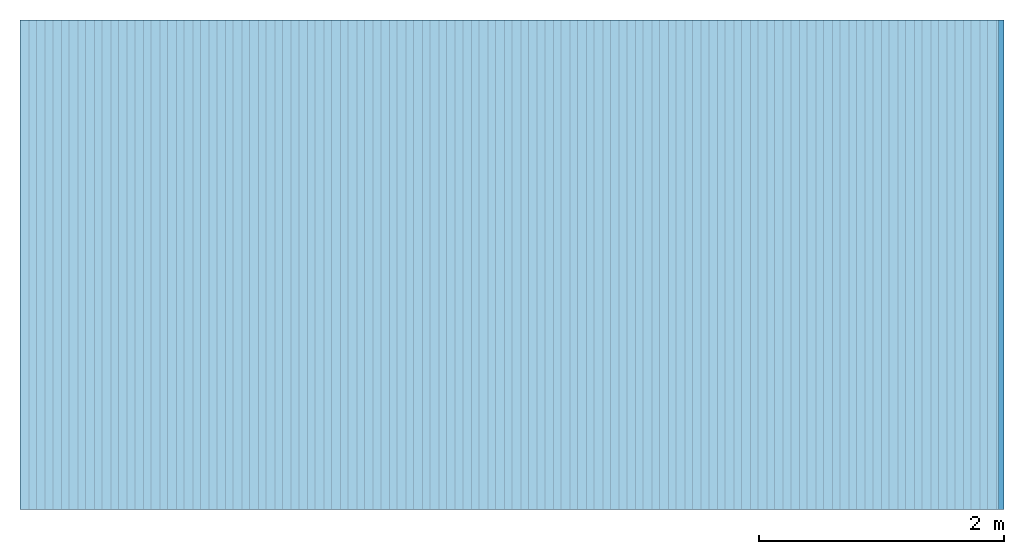
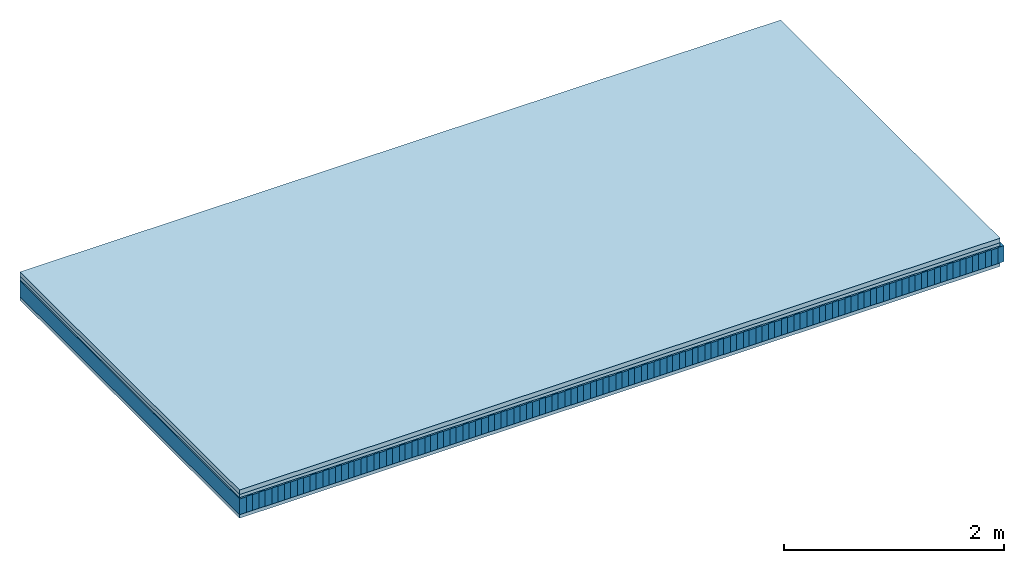
# One storey: 4 plates, 2 members, 1 element without a shape of its own.
"""IFC4 building model written with IfcOpenShell, lengths in metres."""

from ifc_helpers import new_model, si_unit, derived_unit, direction, frame, frame_2d, origin, origin_with_axes, place, context, project, spatial, rectangle, extrude, material, layer, layer_set, type_object, element, aggregate, save


model = new_model("IFC4")

# Units and contexts
plan_context = context("Plan", 3, precision=1e-05, world=origin(), true_north=direction((0.0, 1.0)))
model_context = context("Model", 3, precision=1e-05, world=origin(), true_north=direction((0.0, 1.0)))
ifc_project = project(units=[si_unit("LENGTHUNIT", "METRE"), derived_unit("SOUNDPRESSUREUNIT", [(si_unit("PRESSUREUNIT", "PASCAL", prefix="MICRO"), 0)]), si_unit("ENERGYUNIT", "JOULE", prefix="MEGA"), si_unit("MASSUNIT", "GRAM", prefix="KILO"), derived_unit("THERMALTRANSMITTANCEUNIT", [(si_unit("POWERUNIT", "WATT"), 1), (si_unit("AREAUNIT", "SQUARE_METRE"), -1), (si_unit("THERMODYNAMICTEMPERATUREUNIT", "KELVIN"), -1)]), derived_unit("AREADENSITYUNIT", [(si_unit("MASSUNIT", "GRAM", prefix="KILO"), 1), (si_unit("AREAUNIT", "SQUARE_METRE"), -1)]), derived_unit("USERDEFINED", [(si_unit("ENERGYUNIT", "JOULE", prefix="MEGA"), 1), (si_unit("AREAUNIT", "SQUARE_METRE"), -1)])], contexts=[plan_context, model_context])

# Site, building, storey
site = spatial("IfcSite", under=ifc_project)
building_placement = place(None, origin())
building = spatial("IfcBuilding", under=site, at=building_placement)
storey_placement = place(building_placement, origin())
storey = spatial("IfcBuildingStorey", under=building, at=storey_placement)

# Slab, members, plates
ifc_material_1 = material(Name="Cement screed", Category="04.006")
ifc_layer_1 = layer(ifc_material_1, 0.05, Name="On-material")
ifc_material_2 = material(Name="EP1, 40/35mm")
ifc_layer_2 = layer(ifc_material_2, 0.035, Name="Impact sound insulation")
ifc_material_3 = material(Name="Standard-n", Category="10.009")
ifc_layer_3 = layer(ifc_material_3, 0.015, Name="Additional insulation")
ifc_material_4 = material(Name="Rigid, of the art")
ifc_layer_4 = layer(ifc_material_4, 0.0, Name="Bond")
ifc_layer_5 = layer(None, 0.175, Name="Supporting structure")
ifc_layer_6 = layer(ifc_material_4, 0.0, Name="Bond")
ifc_material_5 = material(Name="panel on the underside HBF 40mm (20+20mm)", Category="07.001")
ifc_layer_7 = layer(ifc_material_5, 0.039, Name="Lower layer 1")
ifc_layer_set = layer_set([ifc_layer_1, ifc_layer_2, ifc_layer_3, ifc_layer_4, ifc_layer_5, ifc_layer_6, ifc_layer_7])
slab_type = type_object("IfcSlabType", Name="A0045", PredefinedType="NOTDEFINED", material=ifc_layer_set)
slab_placement = place(None, frame((0.0, 0.0, 0.0), z_axis=(0.0, 0.0, -1.0), x_axis=(1.0, 0.0, 0.0)))
slab = element("IfcSlab", 1, at=slab_placement, inside=storey, type_object=slab_type, material=ifc_layer_set, Name="Slab #1")
ifc_material_6 = material(Name="Ribs Q3")
member_1_placement = place(slab_placement, origin())
member_1 = element("IfcMember", 2, at=member_1_placement, material=ifc_material_6, Name="Supporting structure", context=plan_context, shape_type="SweptSolid", body=[
    extrude(rectangle(XDim=0.071666666666667, YDim=0.175, at=frame_2d((0.0358333333333335, 0.0875), x_axis=(1.0, 0.0))), frame((0.0, 4.0, 0.1), z_axis=(0.0, -1.0, 0.0), x_axis=(1.0, 0.0, 0.0)), (0.0, 0.0, 1.0), 4.0),
    extrude(rectangle(XDim=0.071666666666667, YDim=0.175, at=frame_2d((0.0358333333333335, 0.0875), x_axis=(1.0, 0.0))), frame((0.134, 4.0, 0.1), z_axis=(0.0, -1.0, 0.0), x_axis=(1.0, 0.0, 0.0)), (0.0, 0.0, 1.0), 4.0),
    extrude(rectangle(XDim=0.071666666666667, YDim=0.175, at=frame_2d((0.0358333333333335, 0.0875), x_axis=(1.0, 0.0))), frame((0.268, 4.0, 0.1), z_axis=(0.0, -1.0, 0.0), x_axis=(1.0, 0.0, 0.0)), (0.0, 0.0, 1.0), 4.0),
    extrude(rectangle(XDim=0.071666666666667, YDim=0.175, at=frame_2d((0.0358333333333335, 0.0875), x_axis=(1.0, 0.0))), frame((0.402, 4.0, 0.1), z_axis=(0.0, -1.0, 0.0), x_axis=(1.0, 0.0, 0.0)), (0.0, 0.0, 1.0), 4.0),
    extrude(rectangle(XDim=0.071666666666667, YDim=0.175, at=frame_2d((0.0358333333333335, 0.0875), x_axis=(1.0, 0.0))), frame((0.536, 4.0, 0.1), z_axis=(0.0, -1.0, 0.0), x_axis=(1.0, 0.0, 0.0)), (0.0, 0.0, 1.0), 4.0),
    extrude(rectangle(XDim=0.071666666666667, YDim=0.175, at=frame_2d((0.0358333333333335, 0.0875), x_axis=(1.0, 0.0))), frame((0.67, 4.0, 0.1), z_axis=(0.0, -1.0, 0.0), x_axis=(1.0, 0.0, 0.0)), (0.0, 0.0, 1.0), 4.0),
    extrude(rectangle(XDim=0.071666666666667, YDim=0.175, at=frame_2d((0.0358333333333335, 0.0875), x_axis=(1.0, 0.0))), frame((0.804, 4.0, 0.1), z_axis=(0.0, -1.0, 0.0), x_axis=(1.0, 0.0, 0.0)), (0.0, 0.0, 1.0), 4.0),
    extrude(rectangle(XDim=0.071666666666667, YDim=0.175, at=frame_2d((0.0358333333333335, 0.0875), x_axis=(1.0, 0.0))), frame((0.938, 4.0, 0.1), z_axis=(0.0, -1.0, 0.0), x_axis=(1.0, 0.0, 0.0)), (0.0, 0.0, 1.0), 4.0),
    extrude(rectangle(XDim=0.071666666666667, YDim=0.175, at=frame_2d((0.0358333333333335, 0.0875), x_axis=(1.0, 0.0))), frame((1.072, 4.0, 0.1), z_axis=(0.0, -1.0, 0.0), x_axis=(1.0, 0.0, 0.0)), (0.0, 0.0, 1.0), 4.0),
    extrude(rectangle(XDim=0.071666666666667, YDim=0.175, at=frame_2d((0.0358333333333335, 0.0875), x_axis=(1.0, 0.0))), frame((1.206, 4.0, 0.1), z_axis=(0.0, -1.0, 0.0), x_axis=(1.0, 0.0, 0.0)), (0.0, 0.0, 1.0), 4.0),
    extrude(rectangle(XDim=0.071666666666667, YDim=0.175, at=frame_2d((0.0358333333333335, 0.0875), x_axis=(1.0, 0.0))), frame((1.34, 4.0, 0.1), z_axis=(0.0, -1.0, 0.0), x_axis=(1.0, 0.0, 0.0)), (0.0, 0.0, 1.0), 4.0),
    extrude(rectangle(XDim=0.071666666666667, YDim=0.175, at=frame_2d((0.0358333333333335, 0.0875), x_axis=(1.0, 0.0))), frame((1.474, 4.0, 0.1), z_axis=(0.0, -1.0, 0.0), x_axis=(1.0, 0.0, 0.0)), (0.0, 0.0, 1.0), 4.0),
    extrude(rectangle(XDim=0.071666666666667, YDim=0.175, at=frame_2d((0.0358333333333335, 0.0875), x_axis=(1.0, 0.0))), frame((1.608, 4.0, 0.1), z_axis=(0.0, -1.0, 0.0), x_axis=(1.0, 0.0, 0.0)), (0.0, 0.0, 1.0), 4.0),
    extrude(rectangle(XDim=0.071666666666667, YDim=0.175, at=frame_2d((0.0358333333333335, 0.0875), x_axis=(1.0, 0.0))), frame((1.742, 4.0, 0.1), z_axis=(0.0, -1.0, 0.0), x_axis=(1.0, 0.0, 0.0)), (0.0, 0.0, 1.0), 4.0),
    extrude(rectangle(XDim=0.071666666666667, YDim=0.175, at=frame_2d((0.0358333333333335, 0.0875), x_axis=(1.0, 0.0))), frame((1.876, 4.0, 0.1), z_axis=(0.0, -1.0, 0.0), x_axis=(1.0, 0.0, 0.0)), (0.0, 0.0, 1.0), 4.0),
    extrude(rectangle(XDim=0.071666666666667, YDim=0.175, at=frame_2d((0.0358333333333335, 0.0875), x_axis=(1.0, 0.0))), frame((2.01, 4.0, 0.1), z_axis=(0.0, -1.0, 0.0), x_axis=(1.0, 0.0, 0.0)), (0.0, 0.0, 1.0), 4.0),
    extrude(rectangle(XDim=0.071666666666667, YDim=0.175, at=frame_2d((0.0358333333333335, 0.0875), x_axis=(1.0, 0.0))), frame((2.144, 4.0, 0.1), z_axis=(0.0, -1.0, 0.0), x_axis=(1.0, 0.0, 0.0)), (0.0, 0.0, 1.0), 4.0),
    extrude(rectangle(XDim=0.071666666666667, YDim=0.175, at=frame_2d((0.0358333333333335, 0.0875), x_axis=(1.0, 0.0))), frame((2.278, 4.0, 0.1), z_axis=(0.0, -1.0, 0.0), x_axis=(1.0, 0.0, 0.0)), (0.0, 0.0, 1.0), 4.0),
    extrude(rectangle(XDim=0.071666666666667, YDim=0.175, at=frame_2d((0.0358333333333335, 0.0875), x_axis=(1.0, 0.0))), frame((2.412, 4.0, 0.1), z_axis=(0.0, -1.0, 0.0), x_axis=(1.0, 0.0, 0.0)), (0.0, 0.0, 1.0), 4.0),
    extrude(rectangle(XDim=0.071666666666667, YDim=0.175, at=frame_2d((0.0358333333333335, 0.0875), x_axis=(1.0, 0.0))), frame((2.546, 4.0, 0.1), z_axis=(0.0, -1.0, 0.0), x_axis=(1.0, 0.0, 0.0)), (0.0, 0.0, 1.0), 4.0),
    extrude(rectangle(XDim=0.071666666666667, YDim=0.175, at=frame_2d((0.0358333333333335, 0.0875), x_axis=(1.0, 0.0))), frame((2.68, 4.0, 0.1), z_axis=(0.0, -1.0, 0.0), x_axis=(1.0, 0.0, 0.0)), (0.0, 0.0, 1.0), 4.0),
    extrude(rectangle(XDim=0.071666666666667, YDim=0.175, at=frame_2d((0.0358333333333335, 0.0875), x_axis=(1.0, 0.0))), frame((2.814, 4.0, 0.1), z_axis=(0.0, -1.0, 0.0), x_axis=(1.0, 0.0, 0.0)), (0.0, 0.0, 1.0), 4.0),
    extrude(rectangle(XDim=0.071666666666667, YDim=0.175, at=frame_2d((0.0358333333333335, 0.0875), x_axis=(1.0, 0.0))), frame((2.948, 4.0, 0.1), z_axis=(0.0, -1.0, 0.0), x_axis=(1.0, 0.0, 0.0)), (0.0, 0.0, 1.0), 4.0),
    extrude(rectangle(XDim=0.071666666666667, YDim=0.175, at=frame_2d((0.0358333333333335, 0.0875), x_axis=(1.0, 0.0))), frame((3.082, 4.0, 0.1), z_axis=(0.0, -1.0, 0.0), x_axis=(1.0, 0.0, 0.0)), (0.0, 0.0, 1.0), 4.0),
    extrude(rectangle(XDim=0.071666666666667, YDim=0.175, at=frame_2d((0.0358333333333335, 0.0875), x_axis=(1.0, 0.0))), frame((3.216, 4.0, 0.1), z_axis=(0.0, -1.0, 0.0), x_axis=(1.0, 0.0, 0.0)), (0.0, 0.0, 1.0), 4.0),
    extrude(rectangle(XDim=0.071666666666667, YDim=0.175, at=frame_2d((0.0358333333333335, 0.0875), x_axis=(1.0, 0.0))), frame((3.35, 4.0, 0.1), z_axis=(0.0, -1.0, 0.0), x_axis=(1.0, 0.0, 0.0)), (0.0, 0.0, 1.0), 4.0),
    extrude(rectangle(XDim=0.071666666666667, YDim=0.175, at=frame_2d((0.0358333333333335, 0.0875), x_axis=(1.0, 0.0))), frame((3.484, 4.0, 0.1), z_axis=(0.0, -1.0, 0.0), x_axis=(1.0, 0.0, 0.0)), (0.0, 0.0, 1.0), 4.0),
    extrude(rectangle(XDim=0.071666666666667, YDim=0.175, at=frame_2d((0.0358333333333335, 0.0875), x_axis=(1.0, 0.0))), frame((3.618, 4.0, 0.1), z_axis=(0.0, -1.0, 0.0), x_axis=(1.0, 0.0, 0.0)), (0.0, 0.0, 1.0), 4.0),
    extrude(rectangle(XDim=0.071666666666667, YDim=0.175, at=frame_2d((0.0358333333333335, 0.0875), x_axis=(1.0, 0.0))), frame((3.752, 4.0, 0.1), z_axis=(0.0, -1.0, 0.0), x_axis=(1.0, 0.0, 0.0)), (0.0, 0.0, 1.0), 4.0),
    extrude(rectangle(XDim=0.071666666666667, YDim=0.175, at=frame_2d((0.0358333333333335, 0.0875), x_axis=(1.0, 0.0))), frame((3.886, 4.0, 0.1), z_axis=(0.0, -1.0, 0.0), x_axis=(1.0, 0.0, 0.0)), (0.0, 0.0, 1.0), 4.0),
    extrude(rectangle(XDim=0.071666666666667, YDim=0.175, at=frame_2d((0.0358333333333335, 0.0875), x_axis=(1.0, 0.0))), frame((4.02, 4.0, 0.1), z_axis=(0.0, -1.0, 0.0), x_axis=(1.0, 0.0, 0.0)), (0.0, 0.0, 1.0), 4.0),
    extrude(rectangle(XDim=0.071666666666667, YDim=0.175, at=frame_2d((0.0358333333333335, 0.0875), x_axis=(1.0, 0.0))), frame((4.154, 4.0, 0.1), z_axis=(0.0, -1.0, 0.0), x_axis=(1.0, 0.0, 0.0)), (0.0, 0.0, 1.0), 4.0),
    extrude(rectangle(XDim=0.071666666666667, YDim=0.175, at=frame_2d((0.0358333333333335, 0.0875), x_axis=(1.0, 0.0))), frame((4.288, 4.0, 0.1), z_axis=(0.0, -1.0, 0.0), x_axis=(1.0, 0.0, 0.0)), (0.0, 0.0, 1.0), 4.0),
    extrude(rectangle(XDim=0.071666666666667, YDim=0.175, at=frame_2d((0.0358333333333335, 0.0875), x_axis=(1.0, 0.0))), frame((4.422, 4.0, 0.1), z_axis=(0.0, -1.0, 0.0), x_axis=(1.0, 0.0, 0.0)), (0.0, 0.0, 1.0), 4.0),
    extrude(rectangle(XDim=0.071666666666667, YDim=0.175, at=frame_2d((0.0358333333333335, 0.0875), x_axis=(1.0, 0.0))), frame((4.556, 4.0, 0.1), z_axis=(0.0, -1.0, 0.0), x_axis=(1.0, 0.0, 0.0)), (0.0, 0.0, 1.0), 4.0),
    extrude(rectangle(XDim=0.071666666666667, YDim=0.175, at=frame_2d((0.0358333333333335, 0.0875), x_axis=(1.0, 0.0))), frame((4.69, 4.0, 0.1), z_axis=(0.0, -1.0, 0.0), x_axis=(1.0, 0.0, 0.0)), (0.0, 0.0, 1.0), 4.0),
    extrude(rectangle(XDim=0.071666666666667, YDim=0.175, at=frame_2d((0.0358333333333335, 0.0875), x_axis=(1.0, 0.0))), frame((4.824, 4.0, 0.1), z_axis=(0.0, -1.0, 0.0), x_axis=(1.0, 0.0, 0.0)), (0.0, 0.0, 1.0), 4.0),
    extrude(rectangle(XDim=0.071666666666667, YDim=0.175, at=frame_2d((0.0358333333333335, 0.0875), x_axis=(1.0, 0.0))), frame((4.958, 4.0, 0.1), z_axis=(0.0, -1.0, 0.0), x_axis=(1.0, 0.0, 0.0)), (0.0, 0.0, 1.0), 4.0),
    extrude(rectangle(XDim=0.071666666666667, YDim=0.175, at=frame_2d((0.0358333333333335, 0.0875), x_axis=(1.0, 0.0))), frame((5.092, 4.0, 0.1), z_axis=(0.0, -1.0, 0.0), x_axis=(1.0, 0.0, 0.0)), (0.0, 0.0, 1.0), 4.0),
    extrude(rectangle(XDim=0.071666666666667, YDim=0.175, at=frame_2d((0.0358333333333335, 0.0875), x_axis=(1.0, 0.0))), frame((5.226, 4.0, 0.1), z_axis=(0.0, -1.0, 0.0), x_axis=(1.0, 0.0, 0.0)), (0.0, 0.0, 1.0), 4.0),
    extrude(rectangle(XDim=0.071666666666667, YDim=0.175, at=frame_2d((0.0358333333333335, 0.0875), x_axis=(1.0, 0.0))), frame((5.36, 4.0, 0.1), z_axis=(0.0, -1.0, 0.0), x_axis=(1.0, 0.0, 0.0)), (0.0, 0.0, 1.0), 4.0),
    extrude(rectangle(XDim=0.071666666666667, YDim=0.175, at=frame_2d((0.0358333333333335, 0.0875), x_axis=(1.0, 0.0))), frame((5.494, 4.0, 0.1), z_axis=(0.0, -1.0, 0.0), x_axis=(1.0, 0.0, 0.0)), (0.0, 0.0, 1.0), 4.0),
    extrude(rectangle(XDim=0.071666666666667, YDim=0.175, at=frame_2d((0.0358333333333335, 0.0875), x_axis=(1.0, 0.0))), frame((5.628, 4.0, 0.1), z_axis=(0.0, -1.0, 0.0), x_axis=(1.0, 0.0, 0.0)), (0.0, 0.0, 1.0), 4.0),
    extrude(rectangle(XDim=0.071666666666667, YDim=0.175, at=frame_2d((0.0358333333333335, 0.0875), x_axis=(1.0, 0.0))), frame((5.762, 4.0, 0.1), z_axis=(0.0, -1.0, 0.0), x_axis=(1.0, 0.0, 0.0)), (0.0, 0.0, 1.0), 4.0),
    extrude(rectangle(XDim=0.071666666666667, YDim=0.175, at=frame_2d((0.0358333333333335, 0.0875), x_axis=(1.0, 0.0))), frame((5.896, 4.0, 0.1), z_axis=(0.0, -1.0, 0.0), x_axis=(1.0, 0.0, 0.0)), (0.0, 0.0, 1.0), 4.0),
    extrude(rectangle(XDim=0.071666666666667, YDim=0.175, at=frame_2d((0.0358333333333335, 0.0875), x_axis=(1.0, 0.0))), frame((6.03, 4.0, 0.1), z_axis=(0.0, -1.0, 0.0), x_axis=(1.0, 0.0, 0.0)), (0.0, 0.0, 1.0), 4.0),
    extrude(rectangle(XDim=0.071666666666667, YDim=0.175, at=frame_2d((0.0358333333333335, 0.0875), x_axis=(1.0, 0.0))), frame((6.164, 4.0, 0.1), z_axis=(0.0, -1.0, 0.0), x_axis=(1.0, 0.0, 0.0)), (0.0, 0.0, 1.0), 4.0),
    extrude(rectangle(XDim=0.071666666666667, YDim=0.175, at=frame_2d((0.0358333333333335, 0.0875), x_axis=(1.0, 0.0))), frame((6.298, 4.0, 0.1), z_axis=(0.0, -1.0, 0.0), x_axis=(1.0, 0.0, 0.0)), (0.0, 0.0, 1.0), 4.0),
    extrude(rectangle(XDim=0.071666666666667, YDim=0.175, at=frame_2d((0.0358333333333335, 0.0875), x_axis=(1.0, 0.0))), frame((6.432, 4.0, 0.1), z_axis=(0.0, -1.0, 0.0), x_axis=(1.0, 0.0, 0.0)), (0.0, 0.0, 1.0), 4.0),
    extrude(rectangle(XDim=0.071666666666667, YDim=0.175, at=frame_2d((0.0358333333333335, 0.0875), x_axis=(1.0, 0.0))), frame((6.566, 4.0, 0.1), z_axis=(0.0, -1.0, 0.0), x_axis=(1.0, 0.0, 0.0)), (0.0, 0.0, 1.0), 4.0),
    extrude(rectangle(XDim=0.071666666666667, YDim=0.175, at=frame_2d((0.0358333333333335, 0.0875), x_axis=(1.0, 0.0))), frame((6.7, 4.0, 0.1), z_axis=(0.0, -1.0, 0.0), x_axis=(1.0, 0.0, 0.0)), (0.0, 0.0, 1.0), 4.0),
    extrude(rectangle(XDim=0.071666666666667, YDim=0.175, at=frame_2d((0.0358333333333335, 0.0875), x_axis=(1.0, 0.0))), frame((6.834, 4.0, 0.1), z_axis=(0.0, -1.0, 0.0), x_axis=(1.0, 0.0, 0.0)), (0.0, 0.0, 1.0), 4.0),
    extrude(rectangle(XDim=0.071666666666667, YDim=0.175, at=frame_2d((0.0358333333333335, 0.0875), x_axis=(1.0, 0.0))), frame((6.96800000000001, 4.0, 0.1), z_axis=(0.0, -1.0, 0.0), x_axis=(1.0, 0.0, 0.0)), (0.0, 0.0, 1.0), 4.0),
    extrude(rectangle(XDim=0.071666666666667, YDim=0.175, at=frame_2d((0.0358333333333335, 0.0875), x_axis=(1.0, 0.0))), frame((7.10200000000001, 4.0, 0.1), z_axis=(0.0, -1.0, 0.0), x_axis=(1.0, 0.0, 0.0)), (0.0, 0.0, 1.0), 4.0),
    extrude(rectangle(XDim=0.071666666666667, YDim=0.175, at=frame_2d((0.0358333333333335, 0.0875), x_axis=(1.0, 0.0))), frame((7.23600000000001, 4.0, 0.1), z_axis=(0.0, -1.0, 0.0), x_axis=(1.0, 0.0, 0.0)), (0.0, 0.0, 1.0), 4.0),
    extrude(rectangle(XDim=0.071666666666667, YDim=0.175, at=frame_2d((0.0358333333333335, 0.0875), x_axis=(1.0, 0.0))), frame((7.37000000000001, 4.0, 0.1), z_axis=(0.0, -1.0, 0.0), x_axis=(1.0, 0.0, 0.0)), (0.0, 0.0, 1.0), 4.0),
    extrude(rectangle(XDim=0.071666666666667, YDim=0.175, at=frame_2d((0.0358333333333335, 0.0875), x_axis=(1.0, 0.0))), frame((7.50400000000001, 4.0, 0.1), z_axis=(0.0, -1.0, 0.0), x_axis=(1.0, 0.0, 0.0)), (0.0, 0.0, 1.0), 4.0),
    extrude(rectangle(XDim=0.071666666666667, YDim=0.175, at=frame_2d((0.0358333333333335, 0.0875), x_axis=(1.0, 0.0))), frame((7.63800000000001, 4.0, 0.1), z_axis=(0.0, -1.0, 0.0), x_axis=(1.0, 0.0, 0.0)), (0.0, 0.0, 1.0), 4.0),
    extrude(rectangle(XDim=0.071666666666667, YDim=0.175, at=frame_2d((0.0358333333333335, 0.0875), x_axis=(1.0, 0.0))), frame((7.77200000000001, 4.0, 0.1), z_axis=(0.0, -1.0, 0.0), x_axis=(1.0, 0.0, 0.0)), (0.0, 0.0, 1.0), 4.0),
    extrude(rectangle(XDim=0.071666666666667, YDim=0.175, at=frame_2d((0.0358333333333335, 0.0875), x_axis=(1.0, 0.0))), frame((7.90600000000001, 4.0, 0.1), z_axis=(0.0, -1.0, 0.0), x_axis=(1.0, 0.0, 0.0)), (0.0, 0.0, 1.0), 4.0),
])
ifc_material_7 = material(Name="Gravel of lime 3-6 mm")
member_2_placement = place(slab_placement, origin())
member_2 = element("IfcMember", 3, at=member_2_placement, material=ifc_material_7, Name="in supporting structure", context=plan_context, shape_type="SweptSolid", body=[
    extrude(rectangle(XDim=0.062333333333333, YDim=0.178, at=frame_2d((0.0311666666666665, 0.089), x_axis=(1.0, 0.0))), frame((0.071666666666667, 4.0, 0.097), z_axis=(0.0, -1.0, 0.0), x_axis=(1.0, 0.0, 0.0)), (0.0, 0.0, 1.0), 4.0),
    extrude(rectangle(XDim=0.062333333333333, YDim=0.178, at=frame_2d((0.0311666666666665, 0.089), x_axis=(1.0, 0.0))), frame((0.205666666666667, 4.0, 0.097), z_axis=(0.0, -1.0, 0.0), x_axis=(1.0, 0.0, 0.0)), (0.0, 0.0, 1.0), 4.0),
    extrude(rectangle(XDim=0.062333333333333, YDim=0.178, at=frame_2d((0.0311666666666665, 0.089), x_axis=(1.0, 0.0))), frame((0.339666666666667, 4.0, 0.097), z_axis=(0.0, -1.0, 0.0), x_axis=(1.0, 0.0, 0.0)), (0.0, 0.0, 1.0), 4.0),
    extrude(rectangle(XDim=0.062333333333333, YDim=0.178, at=frame_2d((0.0311666666666665, 0.089), x_axis=(1.0, 0.0))), frame((0.473666666666667, 4.0, 0.097), z_axis=(0.0, -1.0, 0.0), x_axis=(1.0, 0.0, 0.0)), (0.0, 0.0, 1.0), 4.0),
    extrude(rectangle(XDim=0.062333333333333, YDim=0.178, at=frame_2d((0.0311666666666665, 0.089), x_axis=(1.0, 0.0))), frame((0.607666666666667, 4.0, 0.097), z_axis=(0.0, -1.0, 0.0), x_axis=(1.0, 0.0, 0.0)), (0.0, 0.0, 1.0), 4.0),
    extrude(rectangle(XDim=0.062333333333333, YDim=0.178, at=frame_2d((0.0311666666666665, 0.089), x_axis=(1.0, 0.0))), frame((0.741666666666667, 4.0, 0.097), z_axis=(0.0, -1.0, 0.0), x_axis=(1.0, 0.0, 0.0)), (0.0, 0.0, 1.0), 4.0),
    extrude(rectangle(XDim=0.062333333333333, YDim=0.178, at=frame_2d((0.0311666666666665, 0.089), x_axis=(1.0, 0.0))), frame((0.875666666666667, 4.0, 0.097), z_axis=(0.0, -1.0, 0.0), x_axis=(1.0, 0.0, 0.0)), (0.0, 0.0, 1.0), 4.0),
    extrude(rectangle(XDim=0.062333333333333, YDim=0.178, at=frame_2d((0.0311666666666665, 0.089), x_axis=(1.0, 0.0))), frame((1.00966666666667, 4.0, 0.097), z_axis=(0.0, -1.0, 0.0), x_axis=(1.0, 0.0, 0.0)), (0.0, 0.0, 1.0), 4.0),
    extrude(rectangle(XDim=0.062333333333333, YDim=0.178, at=frame_2d((0.0311666666666665, 0.089), x_axis=(1.0, 0.0))), frame((1.14366666666667, 4.0, 0.097), z_axis=(0.0, -1.0, 0.0), x_axis=(1.0, 0.0, 0.0)), (0.0, 0.0, 1.0), 4.0),
    extrude(rectangle(XDim=0.062333333333333, YDim=0.178, at=frame_2d((0.0311666666666665, 0.089), x_axis=(1.0, 0.0))), frame((1.27766666666667, 4.0, 0.097), z_axis=(0.0, -1.0, 0.0), x_axis=(1.0, 0.0, 0.0)), (0.0, 0.0, 1.0), 4.0),
    extrude(rectangle(XDim=0.062333333333333, YDim=0.178, at=frame_2d((0.0311666666666665, 0.089), x_axis=(1.0, 0.0))), frame((1.41166666666667, 4.0, 0.097), z_axis=(0.0, -1.0, 0.0), x_axis=(1.0, 0.0, 0.0)), (0.0, 0.0, 1.0), 4.0),
    extrude(rectangle(XDim=0.062333333333333, YDim=0.178, at=frame_2d((0.0311666666666665, 0.089), x_axis=(1.0, 0.0))), frame((1.54566666666667, 4.0, 0.097), z_axis=(0.0, -1.0, 0.0), x_axis=(1.0, 0.0, 0.0)), (0.0, 0.0, 1.0), 4.0),
    extrude(rectangle(XDim=0.062333333333333, YDim=0.178, at=frame_2d((0.0311666666666665, 0.089), x_axis=(1.0, 0.0))), frame((1.67966666666667, 4.0, 0.097), z_axis=(0.0, -1.0, 0.0), x_axis=(1.0, 0.0, 0.0)), (0.0, 0.0, 1.0), 4.0),
    extrude(rectangle(XDim=0.062333333333333, YDim=0.178, at=frame_2d((0.0311666666666665, 0.089), x_axis=(1.0, 0.0))), frame((1.81366666666667, 4.0, 0.097), z_axis=(0.0, -1.0, 0.0), x_axis=(1.0, 0.0, 0.0)), (0.0, 0.0, 1.0), 4.0),
    extrude(rectangle(XDim=0.062333333333333, YDim=0.178, at=frame_2d((0.0311666666666665, 0.089), x_axis=(1.0, 0.0))), frame((1.94766666666667, 4.0, 0.097), z_axis=(0.0, -1.0, 0.0), x_axis=(1.0, 0.0, 0.0)), (0.0, 0.0, 1.0), 4.0),
    extrude(rectangle(XDim=0.062333333333333, YDim=0.178, at=frame_2d((0.0311666666666665, 0.089), x_axis=(1.0, 0.0))), frame((2.08166666666667, 4.0, 0.097), z_axis=(0.0, -1.0, 0.0), x_axis=(1.0, 0.0, 0.0)), (0.0, 0.0, 1.0), 4.0),
    extrude(rectangle(XDim=0.062333333333333, YDim=0.178, at=frame_2d((0.0311666666666665, 0.089), x_axis=(1.0, 0.0))), frame((2.21566666666667, 4.0, 0.097), z_axis=(0.0, -1.0, 0.0), x_axis=(1.0, 0.0, 0.0)), (0.0, 0.0, 1.0), 4.0),
    extrude(rectangle(XDim=0.062333333333333, YDim=0.178, at=frame_2d((0.0311666666666665, 0.089), x_axis=(1.0, 0.0))), frame((2.34966666666667, 4.0, 0.097), z_axis=(0.0, -1.0, 0.0), x_axis=(1.0, 0.0, 0.0)), (0.0, 0.0, 1.0), 4.0),
    extrude(rectangle(XDim=0.062333333333333, YDim=0.178, at=frame_2d((0.0311666666666665, 0.089), x_axis=(1.0, 0.0))), frame((2.48366666666667, 4.0, 0.097), z_axis=(0.0, -1.0, 0.0), x_axis=(1.0, 0.0, 0.0)), (0.0, 0.0, 1.0), 4.0),
    extrude(rectangle(XDim=0.062333333333333, YDim=0.178, at=frame_2d((0.0311666666666665, 0.089), x_axis=(1.0, 0.0))), frame((2.61766666666667, 4.0, 0.097), z_axis=(0.0, -1.0, 0.0), x_axis=(1.0, 0.0, 0.0)), (0.0, 0.0, 1.0), 4.0),
    extrude(rectangle(XDim=0.062333333333333, YDim=0.178, at=frame_2d((0.0311666666666665, 0.089), x_axis=(1.0, 0.0))), frame((2.75166666666667, 4.0, 0.097), z_axis=(0.0, -1.0, 0.0), x_axis=(1.0, 0.0, 0.0)), (0.0, 0.0, 1.0), 4.0),
    extrude(rectangle(XDim=0.062333333333333, YDim=0.178, at=frame_2d((0.0311666666666665, 0.089), x_axis=(1.0, 0.0))), frame((2.88566666666667, 4.0, 0.097), z_axis=(0.0, -1.0, 0.0), x_axis=(1.0, 0.0, 0.0)), (0.0, 0.0, 1.0), 4.0),
    extrude(rectangle(XDim=0.062333333333333, YDim=0.178, at=frame_2d((0.0311666666666665, 0.089), x_axis=(1.0, 0.0))), frame((3.01966666666667, 4.0, 0.097), z_axis=(0.0, -1.0, 0.0), x_axis=(1.0, 0.0, 0.0)), (0.0, 0.0, 1.0), 4.0),
    extrude(rectangle(XDim=0.062333333333333, YDim=0.178, at=frame_2d((0.0311666666666665, 0.089), x_axis=(1.0, 0.0))), frame((3.15366666666667, 4.0, 0.097), z_axis=(0.0, -1.0, 0.0), x_axis=(1.0, 0.0, 0.0)), (0.0, 0.0, 1.0), 4.0),
    extrude(rectangle(XDim=0.062333333333333, YDim=0.178, at=frame_2d((0.0311666666666665, 0.089), x_axis=(1.0, 0.0))), frame((3.28766666666667, 4.0, 0.097), z_axis=(0.0, -1.0, 0.0), x_axis=(1.0, 0.0, 0.0)), (0.0, 0.0, 1.0), 4.0),
    extrude(rectangle(XDim=0.062333333333333, YDim=0.178, at=frame_2d((0.0311666666666665, 0.089), x_axis=(1.0, 0.0))), frame((3.42166666666667, 4.0, 0.097), z_axis=(0.0, -1.0, 0.0), x_axis=(1.0, 0.0, 0.0)), (0.0, 0.0, 1.0), 4.0),
    extrude(rectangle(XDim=0.062333333333333, YDim=0.178, at=frame_2d((0.0311666666666665, 0.089), x_axis=(1.0, 0.0))), frame((3.55566666666666, 4.0, 0.097), z_axis=(0.0, -1.0, 0.0), x_axis=(1.0, 0.0, 0.0)), (0.0, 0.0, 1.0), 4.0),
    extrude(rectangle(XDim=0.062333333333333, YDim=0.178, at=frame_2d((0.0311666666666665, 0.089), x_axis=(1.0, 0.0))), frame((3.68966666666666, 4.0, 0.097), z_axis=(0.0, -1.0, 0.0), x_axis=(1.0, 0.0, 0.0)), (0.0, 0.0, 1.0), 4.0),
    extrude(rectangle(XDim=0.062333333333333, YDim=0.178, at=frame_2d((0.0311666666666665, 0.089), x_axis=(1.0, 0.0))), frame((3.82366666666666, 4.0, 0.097), z_axis=(0.0, -1.0, 0.0), x_axis=(1.0, 0.0, 0.0)), (0.0, 0.0, 1.0), 4.0),
    extrude(rectangle(XDim=0.062333333333333, YDim=0.178, at=frame_2d((0.0311666666666665, 0.089), x_axis=(1.0, 0.0))), frame((3.95766666666666, 4.0, 0.097), z_axis=(0.0, -1.0, 0.0), x_axis=(1.0, 0.0, 0.0)), (0.0, 0.0, 1.0), 4.0),
    extrude(rectangle(XDim=0.062333333333333, YDim=0.178, at=frame_2d((0.0311666666666665, 0.089), x_axis=(1.0, 0.0))), frame((4.09166666666667, 4.0, 0.097), z_axis=(0.0, -1.0, 0.0), x_axis=(1.0, 0.0, 0.0)), (0.0, 0.0, 1.0), 4.0),
    extrude(rectangle(XDim=0.062333333333333, YDim=0.178, at=frame_2d((0.0311666666666665, 0.089), x_axis=(1.0, 0.0))), frame((4.22566666666667, 4.0, 0.097), z_axis=(0.0, -1.0, 0.0), x_axis=(1.0, 0.0, 0.0)), (0.0, 0.0, 1.0), 4.0),
    extrude(rectangle(XDim=0.062333333333333, YDim=0.178, at=frame_2d((0.0311666666666665, 0.089), x_axis=(1.0, 0.0))), frame((4.35966666666667, 4.0, 0.097), z_axis=(0.0, -1.0, 0.0), x_axis=(1.0, 0.0, 0.0)), (0.0, 0.0, 1.0), 4.0),
    extrude(rectangle(XDim=0.062333333333333, YDim=0.178, at=frame_2d((0.0311666666666665, 0.089), x_axis=(1.0, 0.0))), frame((4.49366666666667, 4.0, 0.097), z_axis=(0.0, -1.0, 0.0), x_axis=(1.0, 0.0, 0.0)), (0.0, 0.0, 1.0), 4.0),
    extrude(rectangle(XDim=0.062333333333333, YDim=0.178, at=frame_2d((0.0311666666666665, 0.089), x_axis=(1.0, 0.0))), frame((4.62766666666667, 4.0, 0.097), z_axis=(0.0, -1.0, 0.0), x_axis=(1.0, 0.0, 0.0)), (0.0, 0.0, 1.0), 4.0),
    extrude(rectangle(XDim=0.062333333333333, YDim=0.178, at=frame_2d((0.0311666666666665, 0.089), x_axis=(1.0, 0.0))), frame((4.76166666666667, 4.0, 0.097), z_axis=(0.0, -1.0, 0.0), x_axis=(1.0, 0.0, 0.0)), (0.0, 0.0, 1.0), 4.0),
    extrude(rectangle(XDim=0.062333333333333, YDim=0.178, at=frame_2d((0.0311666666666665, 0.089), x_axis=(1.0, 0.0))), frame((4.89566666666667, 4.0, 0.097), z_axis=(0.0, -1.0, 0.0), x_axis=(1.0, 0.0, 0.0)), (0.0, 0.0, 1.0), 4.0),
    extrude(rectangle(XDim=0.062333333333333, YDim=0.178, at=frame_2d((0.0311666666666665, 0.089), x_axis=(1.0, 0.0))), frame((5.02966666666667, 4.0, 0.097), z_axis=(0.0, -1.0, 0.0), x_axis=(1.0, 0.0, 0.0)), (0.0, 0.0, 1.0), 4.0),
    extrude(rectangle(XDim=0.062333333333333, YDim=0.178, at=frame_2d((0.0311666666666665, 0.089), x_axis=(1.0, 0.0))), frame((5.16366666666667, 4.0, 0.097), z_axis=(0.0, -1.0, 0.0), x_axis=(1.0, 0.0, 0.0)), (0.0, 0.0, 1.0), 4.0),
    extrude(rectangle(XDim=0.062333333333333, YDim=0.178, at=frame_2d((0.0311666666666665, 0.089), x_axis=(1.0, 0.0))), frame((5.29766666666667, 4.0, 0.097), z_axis=(0.0, -1.0, 0.0), x_axis=(1.0, 0.0, 0.0)), (0.0, 0.0, 1.0), 4.0),
    extrude(rectangle(XDim=0.062333333333333, YDim=0.178, at=frame_2d((0.0311666666666665, 0.089), x_axis=(1.0, 0.0))), frame((5.43166666666667, 4.0, 0.097), z_axis=(0.0, -1.0, 0.0), x_axis=(1.0, 0.0, 0.0)), (0.0, 0.0, 1.0), 4.0),
    extrude(rectangle(XDim=0.062333333333333, YDim=0.178, at=frame_2d((0.0311666666666665, 0.089), x_axis=(1.0, 0.0))), frame((5.56566666666667, 4.0, 0.097), z_axis=(0.0, -1.0, 0.0), x_axis=(1.0, 0.0, 0.0)), (0.0, 0.0, 1.0), 4.0),
    extrude(rectangle(XDim=0.062333333333333, YDim=0.178, at=frame_2d((0.0311666666666665, 0.089), x_axis=(1.0, 0.0))), frame((5.69966666666667, 4.0, 0.097), z_axis=(0.0, -1.0, 0.0), x_axis=(1.0, 0.0, 0.0)), (0.0, 0.0, 1.0), 4.0),
    extrude(rectangle(XDim=0.062333333333333, YDim=0.178, at=frame_2d((0.0311666666666665, 0.089), x_axis=(1.0, 0.0))), frame((5.83366666666667, 4.0, 0.097), z_axis=(0.0, -1.0, 0.0), x_axis=(1.0, 0.0, 0.0)), (0.0, 0.0, 1.0), 4.0),
    extrude(rectangle(XDim=0.062333333333333, YDim=0.178, at=frame_2d((0.0311666666666665, 0.089), x_axis=(1.0, 0.0))), frame((5.96766666666667, 4.0, 0.097), z_axis=(0.0, -1.0, 0.0), x_axis=(1.0, 0.0, 0.0)), (0.0, 0.0, 1.0), 4.0),
    extrude(rectangle(XDim=0.062333333333333, YDim=0.178, at=frame_2d((0.0311666666666665, 0.089), x_axis=(1.0, 0.0))), frame((6.10166666666667, 4.0, 0.097), z_axis=(0.0, -1.0, 0.0), x_axis=(1.0, 0.0, 0.0)), (0.0, 0.0, 1.0), 4.0),
    extrude(rectangle(XDim=0.062333333333333, YDim=0.178, at=frame_2d((0.0311666666666665, 0.089), x_axis=(1.0, 0.0))), frame((6.23566666666667, 4.0, 0.097), z_axis=(0.0, -1.0, 0.0), x_axis=(1.0, 0.0, 0.0)), (0.0, 0.0, 1.0), 4.0),
    extrude(rectangle(XDim=0.062333333333333, YDim=0.178, at=frame_2d((0.0311666666666665, 0.089), x_axis=(1.0, 0.0))), frame((6.36966666666667, 4.0, 0.097), z_axis=(0.0, -1.0, 0.0), x_axis=(1.0, 0.0, 0.0)), (0.0, 0.0, 1.0), 4.0),
    extrude(rectangle(XDim=0.062333333333333, YDim=0.178, at=frame_2d((0.0311666666666665, 0.089), x_axis=(1.0, 0.0))), frame((6.50366666666667, 4.0, 0.097), z_axis=(0.0, -1.0, 0.0), x_axis=(1.0, 0.0, 0.0)), (0.0, 0.0, 1.0), 4.0),
    extrude(rectangle(XDim=0.062333333333333, YDim=0.178, at=frame_2d((0.0311666666666665, 0.089), x_axis=(1.0, 0.0))), frame((6.63766666666667, 4.0, 0.097), z_axis=(0.0, -1.0, 0.0), x_axis=(1.0, 0.0, 0.0)), (0.0, 0.0, 1.0), 4.0),
    extrude(rectangle(XDim=0.062333333333333, YDim=0.178, at=frame_2d((0.0311666666666665, 0.089), x_axis=(1.0, 0.0))), frame((6.77166666666667, 4.0, 0.097), z_axis=(0.0, -1.0, 0.0), x_axis=(1.0, 0.0, 0.0)), (0.0, 0.0, 1.0), 4.0),
    extrude(rectangle(XDim=0.062333333333333, YDim=0.178, at=frame_2d((0.0311666666666665, 0.089), x_axis=(1.0, 0.0))), frame((6.90566666666667, 4.0, 0.097), z_axis=(0.0, -1.0, 0.0), x_axis=(1.0, 0.0, 0.0)), (0.0, 0.0, 1.0), 4.0),
    extrude(rectangle(XDim=0.062333333333333, YDim=0.178, at=frame_2d((0.0311666666666665, 0.089), x_axis=(1.0, 0.0))), frame((7.03966666666667, 4.0, 0.097), z_axis=(0.0, -1.0, 0.0), x_axis=(1.0, 0.0, 0.0)), (0.0, 0.0, 1.0), 4.0),
    extrude(rectangle(XDim=0.062333333333333, YDim=0.178, at=frame_2d((0.0311666666666665, 0.089), x_axis=(1.0, 0.0))), frame((7.17366666666667, 4.0, 0.097), z_axis=(0.0, -1.0, 0.0), x_axis=(1.0, 0.0, 0.0)), (0.0, 0.0, 1.0), 4.0),
    extrude(rectangle(XDim=0.062333333333333, YDim=0.178, at=frame_2d((0.0311666666666665, 0.089), x_axis=(1.0, 0.0))), frame((7.30766666666667, 4.0, 0.097), z_axis=(0.0, -1.0, 0.0), x_axis=(1.0, 0.0, 0.0)), (0.0, 0.0, 1.0), 4.0),
    extrude(rectangle(XDim=0.062333333333333, YDim=0.178, at=frame_2d((0.0311666666666665, 0.089), x_axis=(1.0, 0.0))), frame((7.44166666666667, 4.0, 0.097), z_axis=(0.0, -1.0, 0.0), x_axis=(1.0, 0.0, 0.0)), (0.0, 0.0, 1.0), 4.0),
    extrude(rectangle(XDim=0.062333333333333, YDim=0.178, at=frame_2d((0.0311666666666665, 0.089), x_axis=(1.0, 0.0))), frame((7.57566666666667, 4.0, 0.097), z_axis=(0.0, -1.0, 0.0), x_axis=(1.0, 0.0, 0.0)), (0.0, 0.0, 1.0), 4.0),
    extrude(rectangle(XDim=0.062333333333333, YDim=0.178, at=frame_2d((0.0311666666666665, 0.089), x_axis=(1.0, 0.0))), frame((7.70966666666667, 4.0, 0.097), z_axis=(0.0, -1.0, 0.0), x_axis=(1.0, 0.0, 0.0)), (0.0, 0.0, 1.0), 4.0),
    extrude(rectangle(XDim=0.062333333333333, YDim=0.178, at=frame_2d((0.0311666666666665, 0.089), x_axis=(1.0, 0.0))), frame((7.84366666666667, 4.0, 0.097), z_axis=(0.0, -1.0, 0.0), x_axis=(1.0, 0.0, 0.0)), (0.0, 0.0, 1.0), 4.0),
    extrude(rectangle(XDim=0.062333333333333, YDim=0.178, at=frame_2d((0.0311666666666665, 0.089), x_axis=(1.0, 0.0))), frame((7.97766666666667, 4.0, 0.097), z_axis=(0.0, -1.0, 0.0), x_axis=(1.0, 0.0, 0.0)), (0.0, 0.0, 1.0), 4.0),
])
plate_1_placement = place(slab_placement, origin())
plate_1 = element("IfcPlate", 4, at=plate_1_placement, material=ifc_material_1, Name="On-material", context=plan_context, shape_type="SweptSolid", body=[
    extrude(rectangle(XDim=8.0, YDim=4.0, at=frame_2d((4.0, 2.0), x_axis=(1.0, 0.0))), origin_with_axes(), (0.0, 0.0, 1.0), 0.05),
])
plate_2_placement = place(slab_placement, origin())
plate_2 = element("IfcPlate", 5, at=plate_2_placement, material=ifc_material_2, Name="Impact sound insulation", context=plan_context, shape_type="SweptSolid", body=[
    extrude(rectangle(XDim=8.0, YDim=4.0, at=frame_2d((4.0, 2.0), x_axis=(1.0, 0.0))), frame((0.0, 0.0, 0.05), z_axis=(0.0, 0.0, 1.0), x_axis=(1.0, 0.0, 0.0)), (0.0, 0.0, 1.0), 0.035),
])
plate_3_placement = place(slab_placement, origin())
plate_3 = element("IfcPlate", 6, at=plate_3_placement, material=ifc_material_3, Name="Additional insulation", context=plan_context, shape_type="SweptSolid", body=[
    extrude(rectangle(XDim=8.0, YDim=4.0, at=frame_2d((4.0, 2.0), x_axis=(1.0, 0.0))), frame((0.0, 0.0, 0.085), z_axis=(0.0, 0.0, 1.0), x_axis=(1.0, 0.0, 0.0)), (0.0, 0.0, 1.0), 0.015),
])
plate_4_placement = place(slab_placement, origin())
plate_4 = element("IfcPlate", 7, at=plate_4_placement, material=ifc_material_5, Name="Lower layer 1", context=plan_context, shape_type="SweptSolid", body=[
    extrude(rectangle(XDim=8.0, YDim=4.0, at=frame_2d((4.0, 2.0), x_axis=(1.0, 0.0))), frame((0.0, 0.0, 0.275), z_axis=(0.0, 0.0, 1.0), x_axis=(1.0, 0.0, 0.0)), (0.0, 0.0, 1.0), 0.039),
])
aggregate(slab, [plate_1, plate_2, plate_3, member_1, member_2, plate_4])

save(model, "model.ifc")
